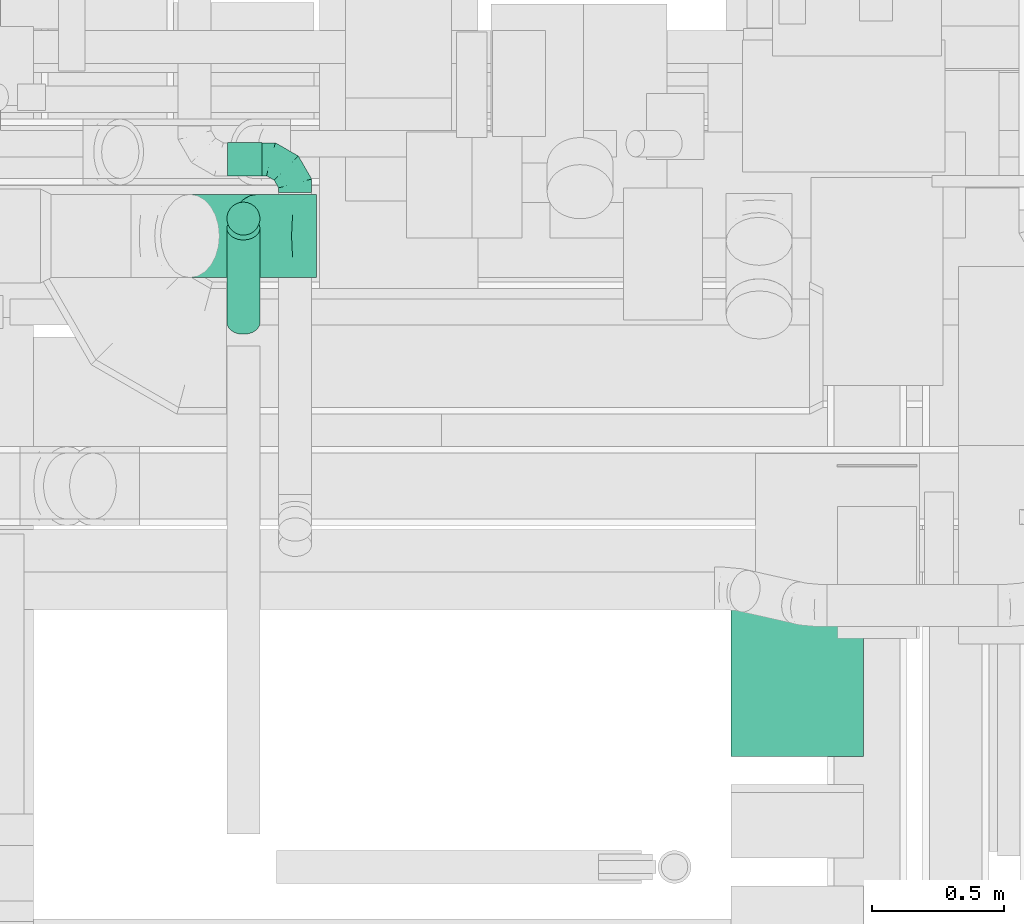
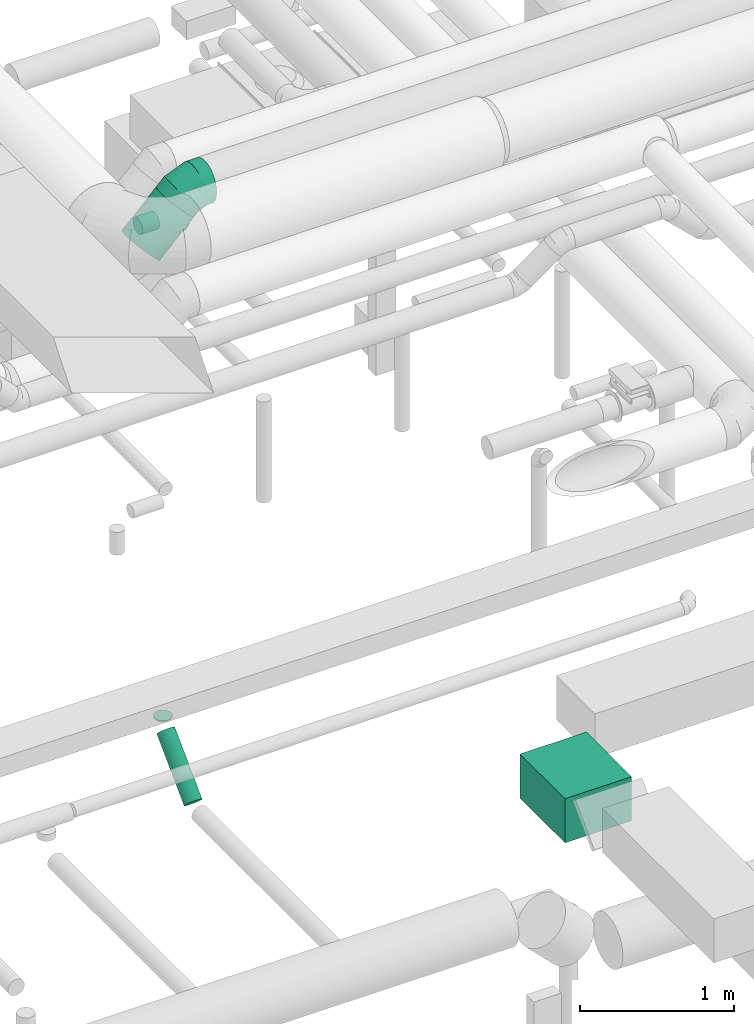
# One storey, part 179 of 337: 5 flow segments, 2 flow fittings.
"""IFC2X3 building model written with IfcOpenShell, lengths in millimetres."""

from ifc_helpers import new_model, entity, si_unit, converted_unit, derived_unit, direction, frame, origin, origin_2d_with_axis, place, context, subcontext, project, spatial, rectangle, circle, extrude, faceted_brep, source, transform, mapped, material, type_object, type_shapes, element, save


model = new_model("IFC2X3")

# Units and contexts
model_context = context("Model", 3, precision=0.01, world=origin(), true_north=direction((6.12303176911189e-17, 1.0)))
body_context = subcontext(model_context, "Body", "Model", "MODEL_VIEW")
ifc_project = project(units=[si_unit("LENGTHUNIT", "METRE", prefix="MILLI"), si_unit("AREAUNIT", "SQUARE_METRE"), si_unit("VOLUMEUNIT", "CUBIC_METRE"), converted_unit("PLANEANGLEUNIT", "DEGREE", entity("IfcRatioMeasure", 0.0174532925199433), si_unit("PLANEANGLEUNIT", "RADIAN"), dimensions=[0, 0, 0, 0, 0, 0, 0]), si_unit("MASSUNIT", "GRAM", prefix="KILO"), derived_unit("MASSDENSITYUNIT", [(si_unit("MASSUNIT", "GRAM", prefix="KILO"), 1), (si_unit("LENGTHUNIT", "METRE"), -3)]), derived_unit("MOMENTOFINERTIAUNIT", [(si_unit("LENGTHUNIT", "METRE"), 4)]), si_unit("TIMEUNIT", "SECOND"), si_unit("FREQUENCYUNIT", "HERTZ"), si_unit("THERMODYNAMICTEMPERATUREUNIT", "DEGREE_CELSIUS"), derived_unit("THERMALTRANSMITTANCEUNIT", [(si_unit("MASSUNIT", "GRAM", prefix="KILO"), 1), (si_unit("THERMODYNAMICTEMPERATUREUNIT", "KELVIN"), -1), (si_unit("TIMEUNIT", "SECOND"), -3)]), derived_unit("VOLUMETRICFLOWRATEUNIT", [(si_unit("LENGTHUNIT", "METRE"), 3), (si_unit("TIMEUNIT", "SECOND"), -1)]), derived_unit("MASSFLOWRATEUNIT", [(si_unit("MASSUNIT", "GRAM", prefix="KILO"), 1), (si_unit("TIMEUNIT", "SECOND"), -1)]), derived_unit("ROTATIONALFREQUENCYUNIT", [(si_unit("TIMEUNIT", "SECOND"), -1)]), si_unit("ELECTRICCURRENTUNIT", "AMPERE"), si_unit("ELECTRICVOLTAGEUNIT", "VOLT"), si_unit("POWERUNIT", "WATT"), si_unit("FORCEUNIT", "NEWTON", prefix="KILO"), si_unit("ILLUMINANCEUNIT", "LUX"), si_unit("LUMINOUSFLUXUNIT", "LUMEN"), si_unit("LUMINOUSINTENSITYUNIT", "CANDELA"), derived_unit("USERDEFINED", [(si_unit("MASSUNIT", "GRAM", prefix="KILO"), -1), (si_unit("LENGTHUNIT", "METRE"), -2), (si_unit("TIMEUNIT", "SECOND"), 3), (si_unit("LUMINOUSFLUXUNIT", "LUMEN"), 1)]), derived_unit("LINEARVELOCITYUNIT", [(si_unit("LENGTHUNIT", "METRE"), 1), (si_unit("TIMEUNIT", "SECOND"), -1)]), si_unit("PRESSUREUNIT", "PASCAL"), derived_unit("USERDEFINED", [(si_unit("LENGTHUNIT", "METRE"), -2), (si_unit("MASSUNIT", "GRAM", prefix="KILO"), 1), (si_unit("TIMEUNIT", "SECOND"), -2)]), derived_unit("LINEARFORCEUNIT", [(si_unit("MASSUNIT", "GRAM", prefix="KILO"), 1), (si_unit("LENGTHUNIT", "METRE"), 1), (si_unit("TIMEUNIT", "SECOND"), -2), (si_unit("LENGTHUNIT", "METRE"), -1)]), derived_unit("PLANARFORCEUNIT", [(si_unit("MASSUNIT", "GRAM", prefix="KILO"), 1), (si_unit("LENGTHUNIT", "METRE"), 1), (si_unit("TIMEUNIT", "SECOND"), -2), (si_unit("LENGTHUNIT", "METRE"), -2)])], contexts=[model_context])

# Site, building, storey
site_placement = place(None, origin())
site = spatial("IfcSite", under=ifc_project, at=site_placement, CompositionType="ELEMENT")
building_placement = place(site_placement, origin())
building = spatial("IfcBuilding", under=site, at=building_placement, CompositionType="ELEMENT")
storey_placement = place(building_placement, origin())
storey = spatial("IfcBuildingStorey", under=building, at=storey_placement, CompositionType="ELEMENT", Elevation=0.0)

# Flow segments
duct_segment_type_1 = type_object("IfcDuctSegmentType", PredefinedType="NOTDEFINED")
flow_segment_1_placement = place(storey_placement, frame((49213.6, 7564.08, -1095.0)))
element("IfcFlowSegment", 1, at=flow_segment_1_placement, inside=storey, type_object=duct_segment_type_1, context=body_context, shape_type="SweptSolid", body=[
    extrude(rectangle(XDim=586.289807584145, YDim=499.999999999999, at=origin_2d_with_axis()), frame((250.0, 293.14, 0.0), z_axis=(0.0, 0.0, 1.0), x_axis=(0.0, -1.0, 0.0)), (0.0, 0.0, 1.0), 350.0),
])
duct_segment_type_2 = type_object("IfcDuctSegmentType", PredefinedType="NOTDEFINED")
flow_segment_2_placement = place(storey_placement, frame((47304.85, 9534.05, -678.22)))
element("IfcFlowSegment", 2, at=flow_segment_2_placement, inside=storey, type_object=duct_segment_type_2, context=body_context, shape_type="SweptSolid", body=[
    extrude(circle(Radius=62.5, at=origin_2d_with_axis()), frame((64.1, 64.1, 0.0), z_axis=(0.0, 0.0, 1.0), x_axis=(0.0, -1.0, 0.0)), (0.0, 0.0, 1.0), 8.22330470336942),
])
flow_segment_3_placement = place(storey_placement, frame((47054.07, 9373.4, 3059.3)))
element("IfcFlowSegment", 3, at=flow_segment_3_placement, inside=storey, type_object=duct_segment_type_2, context=body_context, shape_type="SweptSolid", body=[
    extrude(circle(Radius=157.5, at=origin_2d_with_axis()), frame((112.96, 159.1, 112.96), z_axis=(0.707106602330058, 0.0, 0.707106960042992), x_axis=(0.0, -1.0, 0.0)), (0.0, 0.0, 1.0), 361.299172408637),
])
flow_segment_4_placement = place(storey_placement, frame((47309.59, 9758.42, 3035.9)))
element("IfcFlowSegment", 4, at=flow_segment_4_placement, inside=storey, type_object=duct_segment_type_2, context=body_context, shape_type="SweptSolid", body=[
    extrude(circle(Radius=62.5, at=origin_2d_with_axis()), frame((0.0, 64.1, 64.1), z_axis=(1.0, 0.0, 0.0), x_axis=(0.0, 1.0, 0.0)), (0.0, 0.0, 1.0), 130.000000000066),
])
flow_segment_5_placement = place(storey_placement, frame((47304.85, 9158.97, -1169.18)))
element("IfcFlowSegment", 5, at=flow_segment_5_placement, inside=storey, type_object=duct_segment_type_2, context=body_context, shape_type="SweptSolid", body=[
    extrude(circle(Radius=62.5, at=origin_2d_with_axis()), frame((64.1, 45.79, 45.79), z_axis=(0.0, 0.707106781186546, 0.707106781186549), x_axis=(-1.0, 0.0, 0.0)), (0.0, 0.0, 1.0), 504.558441227135),
])

# Flow fittings
ifc_material = material()
duct_fitting_type_1 = type_object("IfcDuctFittingType", PredefinedType="NOTDEFINED", material=ifc_material)
shared_shape_1 = source(origin(), body_context, "Body", "Brep", [
    faceted_brep([(-125.0, 0.0, -62.5), (-125.0, -16.18, -60.37), (-125.0, -31.25, -54.13), (-125.0, -44.19, -44.19), (-125.0, -54.13, -31.25), (-125.0, -60.37, -16.18), (-125.0, -62.5, 0.0), (-125.0, -60.37, 16.18), (-125.0, -54.13, 31.25), (-125.0, -44.19, 44.19), (-125.0, -31.25, 54.13), (-125.0, -16.18, 60.37), (-125.0, 0.0, 62.5), (-125.0, 16.18, 60.37), (-125.0, 31.25, 54.13), (-125.0, 44.19, 44.19), (-125.0, 54.13, 31.25), (-125.0, 60.37, 16.18), (-125.0, 62.5, 0.0), (-125.0, 60.37, -16.18), (-125.0, 54.13, -31.25), (-125.0, 44.19, -44.19), (-125.0, 31.25, -54.13), (-125.0, 16.18, -60.37), (-95.84, 16.18, 60.37), (-99.88, 31.25, 54.13), (-91.51, 0.0, 62.5), (-103.35, 44.19, 44.19), (-107.68, 60.37, 16.18), (-108.25, 62.5, 0.0), (-106.01, 54.13, 31.25), (-106.01, 54.13, -31.25), (-103.35, 44.19, -44.19), (-107.68, 60.37, -16.18), (-95.84, 16.18, -60.37), (-91.51, 0.0, -62.5), (-99.88, 31.25, -54.13), (-87.17, -16.18, -60.37), (-83.13, -31.25, -54.13), (-79.66, -44.19, -44.19), (-77.0, -54.13, -31.25), (-75.33, -60.37, -16.18), (-74.76, -62.5, 0.0), (-75.33, -60.37, 16.18), (-77.0, -54.13, 31.25), (-79.66, -44.19, 44.19), (-83.13, -31.25, 54.13), (-87.17, -16.18, 60.37), (-45.34, 45.34, 60.37), (-56.37, 56.37, 54.13), (-33.49, 33.49, 62.5), (-65.85, 65.85, 44.19), (-73.12, 73.12, 31.25), (-77.69, 77.69, 16.18), (-79.25, 79.25, 0.0), (-77.69, 77.69, -16.18), (-73.12, 73.12, -31.25), (-65.85, 65.85, -44.19), (-45.34, 45.34, -60.37), (-33.49, 33.49, -62.5), (-56.37, 56.37, -54.13), (-21.65, 21.65, -60.37), (-10.62, 10.62, -54.13), (-1.14, 1.14, -44.19), (6.13, -6.13, -31.25), (10.7, -10.7, -16.18), (12.26, -12.26, 0.0), (10.7, -10.7, 16.18), (6.13, -6.13, 31.25), (-1.14, 1.14, 44.19), (-10.62, 10.62, 54.13), (-21.65, 21.65, 60.37), (-16.18, 95.84, 60.37), (-31.25, 99.88, 54.13), (0.0, 91.51, 62.5), (-44.19, 103.35, 44.19), (-54.13, 106.01, 31.25), (-60.37, 107.68, 16.18), (-62.5, 108.25, 0.0), (-60.37, 107.68, -16.18), (-54.13, 106.01, -31.25), (-44.19, 103.35, -44.19), (-16.18, 95.84, -60.37), (0.0, 91.51, -62.5), (-31.25, 99.88, -54.13), (16.18, 87.17, -60.37), (31.25, 83.13, -54.13), (44.19, 79.66, -44.19), (54.13, 77.0, -31.25), (60.37, 75.33, -16.18), (62.5, 74.76, 0.0), (60.37, 75.33, 16.18), (54.13, 77.0, 31.25), (44.19, 79.66, 44.19), (31.25, 83.13, 54.13), (16.18, 87.17, 60.37), (-16.18, 125.0, -60.37), (-31.25, 125.0, -54.13), (-44.19, 125.0, -44.19), (-54.13, 125.0, -31.25), (-60.37, 125.0, -16.18), (-62.5, 125.0, 0.0), (-60.37, 125.0, 16.18), (-54.13, 125.0, 31.25), (-44.19, 125.0, 44.19), (-31.25, 125.0, 54.13), (-16.18, 125.0, 60.37), (0.0, 125.0, 62.5), (16.18, 125.0, 60.37), (31.25, 125.0, 54.13), (44.19, 125.0, 44.19), (54.13, 125.0, 31.25), (60.37, 125.0, 16.18), (62.5, 125.0, 0.0), (60.37, 125.0, -16.18), (54.13, 125.0, -31.25), (44.19, 125.0, -44.19), (31.25, 125.0, -54.13), (16.18, 125.0, -60.37), (0.0, 125.0, -62.5)], [[[0, 1, 2, 3, 4, 5, 6, 7, 8, 9, 10, 11, 12, 13, 14, 15, 16, 17, 18, 19, 20, 21, 22, 23]], [[24, 25, 14, 13]], [[26, 24, 13, 12]], [[14, 25, 27, 15]], [[28, 29, 18, 17]], [[30, 28, 17, 16]], [[15, 27, 30, 16]], [[20, 31, 32, 21]], [[33, 31, 20, 19]], [[18, 29, 33, 19]], [[34, 35, 0, 23]], [[36, 34, 23, 22]], [[21, 32, 36, 22]], [[1, 0, 35, 37]], [[2, 1, 37, 38]], [[38, 39, 3, 2]], [[5, 4, 40, 41]], [[6, 5, 41, 42]], [[39, 40, 4, 3]], [[6, 42, 43, 7]], [[7, 43, 44, 8]], [[45, 9, 8, 44]], [[9, 45, 46, 10]], [[10, 46, 47, 11]], [[26, 12, 11, 47]], [[48, 49, 25, 24]], [[50, 48, 24, 26]], [[27, 25, 49, 51]], [[52, 53, 28, 30]], [[51, 52, 30, 27]], [[29, 28, 53, 54]], [[55, 56, 31, 33]], [[54, 55, 33, 29]], [[57, 32, 31, 56]], [[58, 59, 35, 34]], [[60, 58, 34, 36]], [[57, 60, 36, 32]], [[37, 35, 59, 61]], [[38, 37, 61, 62]], [[39, 38, 62, 63]], [[41, 40, 64, 65]], [[42, 41, 65, 66]], [[63, 64, 40, 39]], [[43, 42, 66, 67]], [[44, 43, 67, 68]], [[68, 69, 45, 44]], [[46, 45, 69, 70]], [[47, 46, 70, 71]], [[26, 47, 71, 50]], [[72, 73, 49, 48]], [[74, 72, 48, 50]], [[51, 49, 73, 75]], [[76, 77, 53, 52]], [[75, 76, 52, 51]], [[54, 53, 77, 78]], [[79, 80, 56, 55]], [[78, 79, 55, 54]], [[81, 57, 56, 80]], [[82, 83, 59, 58]], [[84, 82, 58, 60]], [[81, 84, 60, 57]], [[61, 59, 83, 85]], [[62, 61, 85, 86]], [[63, 62, 86, 87]], [[65, 64, 88, 89]], [[66, 65, 89, 90]], [[87, 88, 64, 63]], [[67, 66, 90, 91]], [[68, 67, 91, 92]], [[92, 93, 69, 68]], [[70, 69, 93, 94]], [[71, 70, 94, 95]], [[50, 71, 95, 74]], [[96, 97, 98, 99, 100, 101, 102, 103, 104, 105, 106, 107, 108, 109, 110, 111, 112, 113, 114, 115, 116, 117, 118, 119]], [[72, 74, 107, 106]], [[73, 72, 106, 105]], [[75, 73, 105, 104]], [[77, 76, 103, 102]], [[78, 77, 102, 101]], [[75, 104, 103, 76]], [[78, 101, 100, 79]], [[79, 100, 99, 80]], [[80, 99, 98, 81]], [[96, 119, 83, 82]], [[97, 96, 82, 84]], [[84, 81, 98, 97]], [[83, 119, 118, 85]], [[85, 118, 117, 86]], [[116, 87, 86, 117]], [[88, 115, 114, 89]], [[89, 114, 113, 90]], [[115, 88, 87, 116]], [[91, 90, 113, 112]], [[92, 91, 112, 111]], [[111, 110, 93, 92]], [[95, 94, 109, 108]], [[74, 95, 108, 107]], [[110, 109, 94, 93]]]),
])
type_shapes(duct_fitting_type_1, [shared_shape_1])
flow_fitting_1_placement = place(storey_placement, frame((47564.59, 9822.51, 3100.0), z_axis=(0.0, 0.0, 1.0), x_axis=(0.0, 1.0, 0.0)))
element("IfcFlowFitting", 6, at=flow_fitting_1_placement, inside=storey, type_object=duct_fitting_type_1, material=ifc_material, context=body_context, shape_type="MappedRepresentation", body=[
    mapped(shared_shape_1, transform((0.0, 0.0, 0.0), scale=1.0)),
])
duct_fitting_type_2 = type_object("IfcDuctFittingType", PredefinedType="NOTDEFINED", material=ifc_material)
shared_shape_2 = source(origin(), body_context, "Body", "Brep", [
    faceted_brep([(-130.48, 0.0, -157.5), (-130.48, -40.76, -152.13), (-130.48, -78.75, -136.4), (-130.48, -111.37, -111.37), (-130.48, -136.4, -78.75), (-130.48, -152.13, -40.76), (-130.48, -157.5, 0.0), (-130.48, -152.13, 40.76), (-130.48, -136.4, 78.75), (-130.48, -111.37, 111.37), (-130.48, -78.75, 136.4), (-130.48, -40.76, 152.13), (-130.48, 0.0, 157.5), (-130.48, 40.76, 152.13), (-130.48, 78.75, 136.4), (-130.48, 111.37, 111.37), (-130.48, 136.4, 78.75), (-130.48, 152.13, 40.76), (-130.48, 157.5, 0.0), (-130.48, 152.13, -40.76), (-130.48, 136.4, -78.75), (-130.48, 111.37, -111.37), (-130.48, 78.75, -136.4), (-130.48, 40.76, -152.13), (-75.93, 40.76, 152.13), (-83.48, 78.75, 136.4), (-67.82, 0.0, 157.5), (-89.97, 111.37, 111.37), (-94.95, 136.4, 78.75), (-98.08, 152.13, 40.76), (-99.15, 157.5, 0.0), (-98.08, 152.13, -40.76), (-94.95, 136.4, -78.75), (-89.97, 111.37, -111.37), (-75.93, 40.76, -152.13), (-67.82, 0.0, -157.5), (-83.48, 78.75, -136.4), (-59.71, -40.76, -152.13), (-52.16, -78.75, -136.4), (-45.67, -111.37, -111.37), (-40.69, -136.4, -78.75), (-37.56, -152.13, -40.76), (-36.49, -157.5, 0.0), (-37.56, -152.13, 40.76), (-40.69, -136.4, 78.75), (-45.67, -111.37, 111.37), (-52.16, -78.75, 136.4), (-59.71, -40.76, 152.13), (24.86, 82.51, 152.13), (3.35, 114.72, 136.4), (47.96, 47.96, 157.5), (-15.13, 142.37, 111.37), (-29.31, 163.59, 78.75), (-38.22, 176.93, 40.76), (-41.26, 181.48, 0.0), (-38.22, 176.93, -40.76), (-29.31, 163.59, -78.75), (-15.13, 142.37, -111.37), (24.86, 82.51, -152.13), (47.96, 47.96, -157.5), (3.35, 114.72, -136.4), (71.05, 13.4, -152.13), (92.56, -18.81, -136.4), (111.04, -46.46, -111.37), (125.22, -67.68, -78.75), (134.13, -81.02, -40.76), (137.17, -85.57, 0.0), (134.13, -81.02, 40.76), (125.22, -67.68, 78.75), (111.04, -46.46, 111.37), (92.56, -18.81, 136.4), (71.05, 13.4, 152.13), (92.26, 92.26, 157.5), (63.44, 121.09, 152.13), (36.58, 147.95, 136.4), (13.51, 171.01, 111.37), (-4.19, 188.71, 78.75), (-15.31, 199.84, 40.76), (-19.11, 203.63, 0.0), (-15.31, 199.84, -40.76), (-4.19, 188.71, -78.75), (13.51, 171.01, -111.37), (36.58, 147.95, -136.4), (63.44, 121.09, -152.13), (92.26, 92.26, -157.5), (121.09, 63.44, -152.13), (147.95, 36.58, -136.4), (171.01, 13.51, -111.37), (188.71, -4.19, -78.75), (199.84, -15.31, -40.76), (203.63, -19.11, 0.0), (199.84, -15.31, 40.76), (188.71, -4.19, 78.75), (171.01, 13.51, 111.37), (147.95, 36.58, 136.4), (121.09, 63.44, 152.13)], [[[0, 1, 2, 3, 4, 5, 6, 7, 8, 9, 10, 11, 12, 13, 14, 15, 16, 17, 18, 19, 20, 21, 22, 23]], [[24, 25, 14, 13]], [[26, 24, 13, 12]], [[27, 15, 14, 25]], [[28, 29, 17, 16]], [[28, 16, 15, 27]], [[30, 18, 17, 29]], [[31, 32, 20, 19]], [[30, 31, 19, 18]], [[21, 20, 32, 33]], [[34, 35, 0, 23]], [[36, 34, 23, 22]], [[33, 36, 22, 21]], [[1, 0, 35, 37]], [[2, 1, 37, 38]], [[3, 2, 38, 39]], [[5, 4, 40, 41]], [[6, 5, 41, 42]], [[39, 40, 4, 3]], [[6, 42, 43, 7]], [[7, 43, 44, 8]], [[45, 9, 8, 44]], [[9, 45, 46, 10]], [[10, 46, 47, 11]], [[26, 12, 11, 47]], [[48, 49, 25, 24]], [[50, 48, 24, 26]], [[27, 25, 49, 51]], [[52, 53, 29, 28]], [[51, 52, 28, 27]], [[30, 29, 53, 54]], [[55, 56, 32, 31]], [[54, 55, 31, 30]], [[33, 32, 56, 57]], [[58, 59, 35, 34]], [[60, 58, 34, 36]], [[57, 60, 36, 33]], [[37, 35, 59, 61]], [[38, 37, 61, 62]], [[39, 38, 62, 63]], [[41, 40, 64, 65]], [[42, 41, 65, 66]], [[63, 64, 40, 39]], [[43, 42, 66, 67]], [[44, 43, 67, 68]], [[68, 69, 45, 44]], [[46, 45, 69, 70]], [[47, 46, 70, 71]], [[26, 47, 71, 50]], [[48, 50, 72, 73]], [[49, 48, 73, 74]], [[51, 49, 74, 75]], [[53, 52, 76, 77]], [[54, 53, 77, 78]], [[51, 75, 76, 52]], [[54, 78, 79, 55]], [[55, 79, 80, 56]], [[56, 80, 81, 57]], [[60, 82, 83, 58]], [[58, 83, 84, 59]], [[60, 57, 81, 82]], [[85, 86, 62, 61]], [[84, 85, 61, 59]], [[87, 63, 62, 86]], [[64, 88, 89, 65]], [[65, 89, 90, 66]], [[88, 64, 63, 87]], [[91, 92, 68, 67]], [[90, 91, 67, 66]], [[92, 93, 69, 68]], [[71, 70, 94, 95]], [[50, 71, 95, 72]], [[93, 94, 70, 69]], [[83, 82, 81, 80, 79, 78, 77, 76, 75, 74, 73, 72, 95, 94, 93, 92, 91, 90, 89, 88, 87, 86, 85, 84]]]),
])
type_shapes(duct_fitting_type_2, [shared_shape_2])
flow_fitting_2_placement = place(storey_placement, frame((47514.78, 9532.5, 3520.0), z_axis=(0.0, 1.0, 0.0), x_axis=(0.707106602330012, 0.0, 0.707106960043038)))
element("IfcFlowFitting", 7, at=flow_fitting_2_placement, inside=storey, type_object=duct_fitting_type_2, material=ifc_material, context=body_context, shape_type="MappedRepresentation", body=[
    mapped(shared_shape_2, transform((0.0, 0.0, 0.0), scale=1.0)),
])

save(model, "model.ifc")
